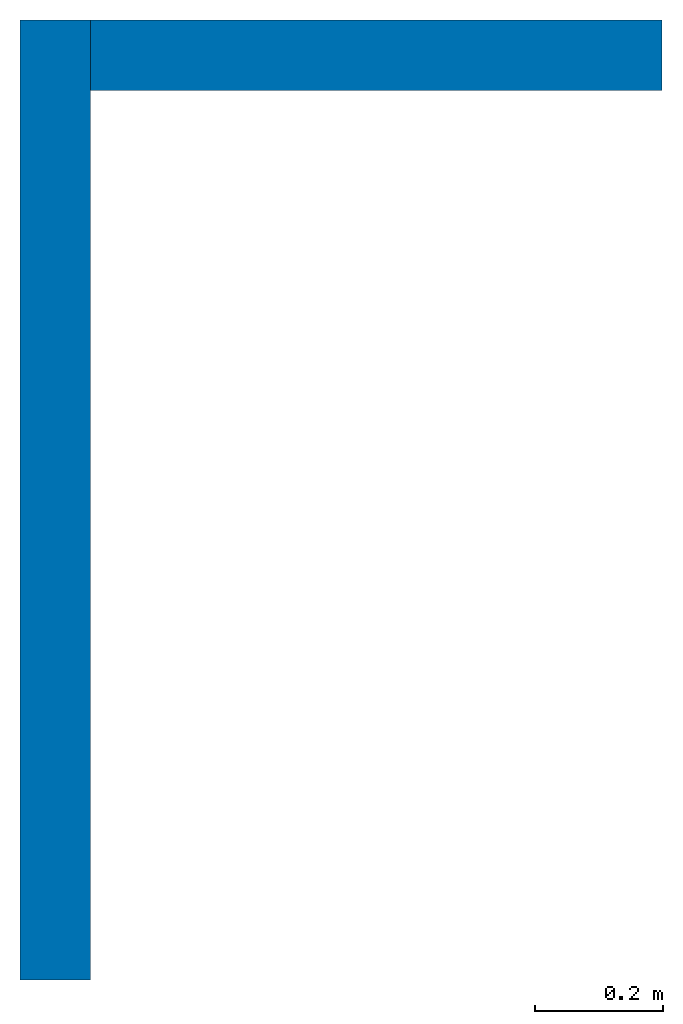
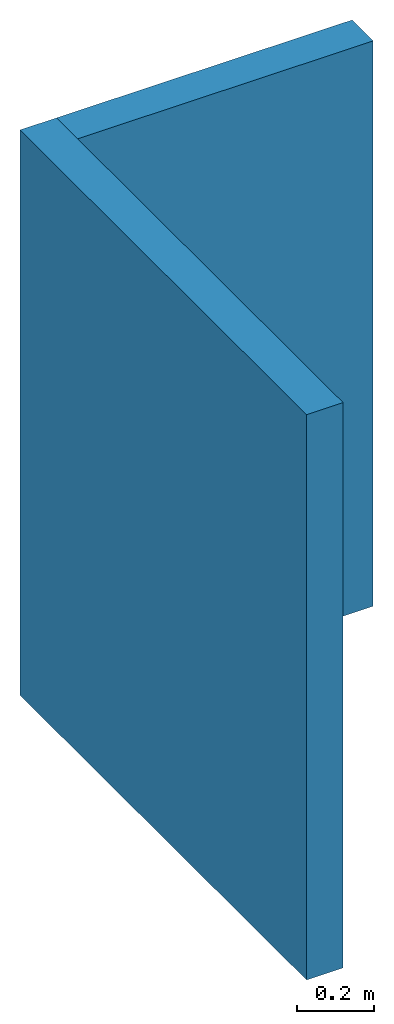
# One storey: 2 walls.
"""IFC2X3 building model written with IfcOpenShell, lengths in metres."""

from ifc_helpers import new_model, entity, si_unit, converted_unit, derived_unit, direction, frame, frame_2d, origin, place, context, subcontext, project, spatial, rectangle, extrude, material, layer, layer_set, layer_usage, type_object, element, save


model = new_model("IFC2X3")

# Units and contexts
model_context = context("Model", 3, precision=1e-05, world=origin(), true_north=direction((6.12303176911189e-17, 1.0)))
body_context = subcontext(model_context, "Body", "Model", "MODEL_VIEW")
ifc_project = project(units=[si_unit("LENGTHUNIT", "METRE"), si_unit("AREAUNIT", "SQUARE_METRE"), si_unit("VOLUMEUNIT", "CUBIC_METRE"), converted_unit("PLANEANGLEUNIT", "DEGREE", entity("IfcRatioMeasure", 0.0174532925199433), si_unit("PLANEANGLEUNIT", "RADIAN"), dimensions=[0, 0, 0, 0, 0, 0, 0]), si_unit("MASSUNIT", "GRAM", prefix="KILO"), derived_unit("MASSDENSITYUNIT", [(si_unit("MASSUNIT", "GRAM", prefix="KILO"), 1), (si_unit("LENGTHUNIT", "METRE"), -3)]), si_unit("TIMEUNIT", "SECOND"), si_unit("FREQUENCYUNIT", "HERTZ"), si_unit("THERMODYNAMICTEMPERATUREUNIT", "DEGREE_CELSIUS"), derived_unit("THERMALTRANSMITTANCEUNIT", [(si_unit("MASSUNIT", "GRAM", prefix="KILO"), 1), (si_unit("THERMODYNAMICTEMPERATUREUNIT", "KELVIN"), -1), (si_unit("TIMEUNIT", "SECOND"), -3)]), derived_unit("VOLUMETRICFLOWRATEUNIT", [(si_unit("LENGTHUNIT", "METRE"), 3), (si_unit("TIMEUNIT", "SECOND"), -1)]), si_unit("ELECTRICCURRENTUNIT", "AMPERE"), si_unit("ELECTRICVOLTAGEUNIT", "VOLT"), si_unit("POWERUNIT", "WATT"), si_unit("FORCEUNIT", "NEWTON", prefix="KILO"), si_unit("ILLUMINANCEUNIT", "LUX"), si_unit("LUMINOUSFLUXUNIT", "LUMEN"), si_unit("LUMINOUSINTENSITYUNIT", "CANDELA"), derived_unit("USERDEFINED", [(si_unit("MASSUNIT", "GRAM", prefix="KILO"), -1), (si_unit("LENGTHUNIT", "METRE"), -2), (si_unit("TIMEUNIT", "SECOND"), 3), (si_unit("LUMINOUSFLUXUNIT", "LUMEN"), 1)]), derived_unit("LINEARVELOCITYUNIT", [(si_unit("LENGTHUNIT", "METRE"), 1), (si_unit("TIMEUNIT", "SECOND"), -1)]), si_unit("PRESSUREUNIT", "PASCAL"), derived_unit("USERDEFINED", [(si_unit("LENGTHUNIT", "METRE"), -2), (si_unit("MASSUNIT", "GRAM", prefix="KILO"), 1), (si_unit("TIMEUNIT", "SECOND"), -2)])], contexts=[model_context])

# Site, building, storey
site_placement = place(None, frame((-5.7744, 33.9036, 0.0)))
site = spatial("IfcSite", under=ifc_project, at=site_placement, CompositionType="ELEMENT")
building_placement = place(site_placement, origin())
building = spatial("IfcBuilding", under=site, at=building_placement, CompositionType="ELEMENT")
storey_placement = place(building_placement, frame((0.0, 0.0, -0.3)))
storey = spatial("IfcBuildingStorey", under=building, at=storey_placement, Name="Foundation", CompositionType="ELEMENT", Elevation=-0.3)

# Walls
ifc_material = material(Name="Brick, Common")
ifc_layer = layer(ifc_material, 0.11)
ifc_layer_set = layer_set([ifc_layer], Name="Basic Wall:Wall")
ifc_layer_usage_1 = layer_usage(ifc_layer_set, "AXIS2", "NEGATIVE", 0.055)
wall_type = type_object("IfcWallType", Name="Basic Wall:Wall", PredefinedType="STANDARD", material=ifc_layer_set)
wall_1_placement = place(storey_placement, frame((0.944999999999999, 2.615, 0.0), z_axis=(0.0, 0.0, 1.0), x_axis=(0.0, 1.0, 0.0)))
element("IfcWallStandardCase", 1, at=wall_1_placement, inside=storey, type_object=wall_type, material=ifc_layer_usage_1, Name="Basic Wall:Wall", ObjectType="Basic Wall:Wall", context=body_context, shape_type="SweptSolid", body=[
    extrude(rectangle(XDim=1.495, YDim=0.11, at=frame_2d((0.747499999999999, -3.46944695195361e-18), x_axis=(-1.0, 0.0))), origin(), (0.0, 0.0, 1.0), 1.8),
])
ifc_layer_usage_2 = layer_usage(ifc_layer_set, "AXIS2", "NEGATIVE", 0.055)
wall_2_placement = place(storey_placement, frame((1.0, 4.055, 0.0)))
element("IfcWallStandardCase", 2, at=wall_2_placement, inside=storey, type_object=wall_type, material=ifc_layer_usage_2, Name="Basic Wall:Wall", ObjectType="Basic Wall:Wall", context=body_context, shape_type="SweptSolid", body=[
    extrude(rectangle(XDim=0.89, YDim=0.11, at=frame_2d((0.445, 9.36750677027476e-17), x_axis=(-1.0, 0.0))), origin(), (0.0, 0.0, 1.0), 1.8),
])

save(model, "model.ifc")
